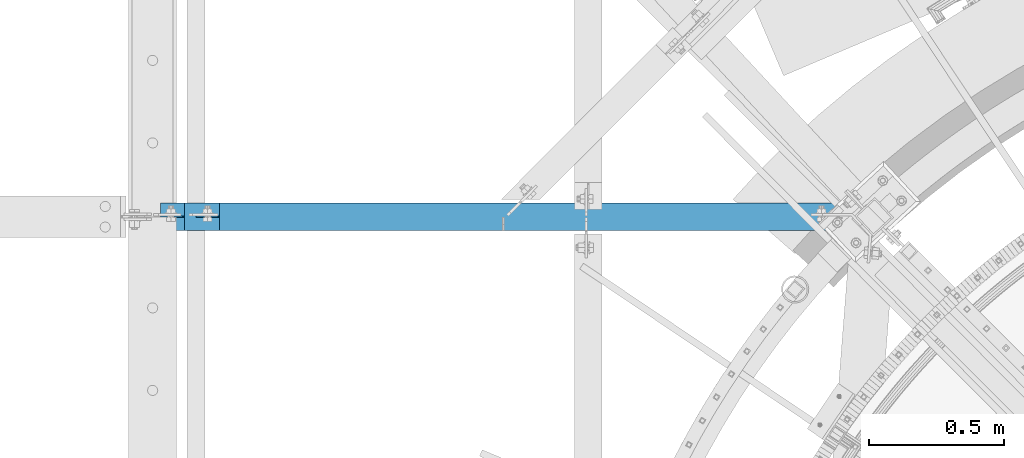
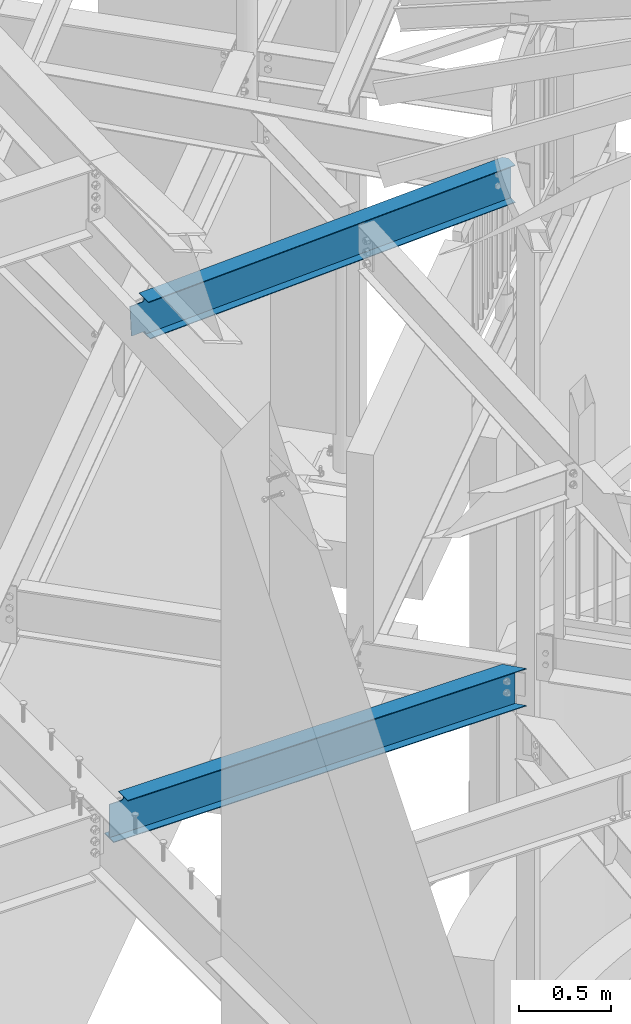
# One storey, part 342 of 975: 2 beams.
"""IFC2X3 building model written with IfcOpenShell, lengths in millimetres."""

from ifc_helpers import new_model, si_unit, frame, origin_with_axes, place, context, subcontext, project, spatial, faceted_brep, material, type_object, element, save


model = new_model("IFC2X3")

# Units and contexts
model_context = context("Model", 3, precision=1e-05, world=origin_with_axes())
body_context = subcontext(model_context, "Body", "Model", "MODEL_VIEW")
ifc_project = project(units=[si_unit("LENGTHUNIT", "METRE", prefix="MILLI"), si_unit("AREAUNIT", "SQUARE_METRE"), si_unit("VOLUMEUNIT", "CUBIC_METRE"), si_unit("MASSUNIT", "GRAM", prefix="KILO"), si_unit("TIMEUNIT", "SECOND"), si_unit("PLANEANGLEUNIT", "RADIAN"), si_unit("SOLIDANGLEUNIT", "STERADIAN"), si_unit("THERMODYNAMICTEMPERATUREUNIT", "DEGREE_CELSIUS"), si_unit("LUMINOUSINTENSITYUNIT", "LUMEN")], contexts=[model_context])

# Site, building, storey
site_placement = place(None, origin_with_axes())
site = spatial("IfcSite", under=ifc_project, at=site_placement, CompositionType="ELEMENT")
building_placement = place(site_placement, origin_with_axes())
building = spatial("IfcBuilding", under=site, at=building_placement, Name="Undefined", CompositionType="ELEMENT")
storey_placement = place(building_placement, origin_with_axes())
storey = spatial("IfcBuildingStorey", under=building, at=storey_placement, Name="Undefined", CompositionType="ELEMENT", Elevation=0.0)

# Beams
ifc_material = material(Name="STEEL/A992")
beam_type = type_object("IfcBeamType", Name="W10X12", PredefinedType="NOTDEFINED")
beam_1_placement = place(storey_placement, frame((29964.9410145014, 5819.77499996243, 7075.61443343476), z_axis=(-0.0449796829949373, 0.0, 0.998987901887543), x_axis=(0.998987901887543, 0.0, 0.0449796829949365)))
element("IfcBeam", 1, at=beam_1_placement, inside=storey, type_object=beam_type, material=ifc_material, Name="BEAM", ObjectType="W10X12", context=body_context, shape_type="Brep", body=[
    faceted_brep([(31.7821272325964, -2.38125000000036, -100.012500000392), (31.7821272325964, 2.38125000000036, -100.012500000392), (107.982127435454, 2.37414132749745, -100.012500000514), (107.982127435454, -2.38125000000036, -100.012500000514), (112.842206953494, 2.37414170163174, -100.979229923104), (112.842206953494, -2.38125000000036, -100.979229923104), (116.962383421644, 2.37413946309971, -103.732243823584), (116.962383421644, -2.38125000000036, -103.732243823584), (119.715397322125, 2.3741349526972, -107.852420291742), (119.715397322125, -2.38125000000036, -107.852420291742), (120.68212724472, -2.38125000000036, -112.71249980979), (120.68212724472, 2.37412885709273, -112.71249980979), (120.682127244723, 2.36192703598772, -120.649999999969), (120.682127244723, 50.8000000000002, -120.649999999969), (120.682127244723, 50.8000000000002, -125.412499999969), (120.682127244723, -50.8000000000002, -125.412499999969), (120.682127244723, -50.8000000000002, -120.649999999969), (120.682127244723, -2.38125000000036, -120.649999999969), (2420.15431038327, 25.1579088831477, -120.650000048678), (2419.93987651427, 25.1579088831477, -125.412499999072), (2396.17930452123, 50.8000000000002, -125.412499999082), (2396.39373728849, 50.8000000000002, -120.64999999908), (2407.25833082956, 50.8000000000002, 120.650000000958), (2431.01890282259, 25.1579088831477, 120.650000000967), (2431.01890282259, 2.38125000000036, 120.650000000967), (120.682127243337, 2.3620972937515, 120.650000011137), (120.682127243341, 50.8000000000002, 120.650000000065), (107.982127434178, -2.38125000000036, 100.012499999661), (107.982127434178, 2.37406664749506, 100.012499999661), (31.7821272324218, 2.38125000000036, 100.012499999564), (31.7821272324218, -2.38125000000036, 100.012499999564), (112.842206952209, -2.38125000000036, 100.979229922245), (112.842206952209, 2.3740673684033, 100.979229922245), (116.962383420345, -2.38125000000036, 103.732243822723), (116.962383420345, 2.37406786749216, 103.732243822723), (119.715397320808, -2.38125000000036, 107.852420290877), (119.715397320808, 2.37406806878062, 107.852420290877), (120.682127243381, -2.38125000000036, 112.712499808924), (120.682127243381, 2.37406794162507, 112.712499808924), (2431.23333558985, -50.8000000000002, 125.412500000969), (2431.23333669159, 25.1579088831477, 125.412499951363), (2407.47276359681, 50.8000000000002, 125.41250000096), (120.682127243337, 50.8000000000002, 125.412500000067), (120.682127243337, -50.8000000000002, 125.412500000067), (2431.01890282259, -50.8000000000002, 120.650000000967), (120.682127243341, -50.8000000000002, 120.650000000065), (2431.01890282259, -2.38125000000036, 120.650000000967), (120.682127243341, -2.38125000000036, 120.650000000065), (2420.15430928153, -2.38125000000036, -120.649999999071), (2420.15430928153, -50.8000000000002, -120.649999999071), (2419.93987651427, -50.8000000000002, -125.412499999072), (2420.15430928153, 2.38125000000036, -120.649999999071)], [[[0, 1, 2, 3]], [[3, 2, 4, 5]], [[5, 4, 6, 7]], [[7, 6, 8, 9]], [[10, 11, 12, 13, 14, 15, 16, 17]], [[9, 8, 11, 10]], [[18, 19, 20, 21]], [[22, 23, 24, 25, 26]], [[27, 28, 29, 30]], [[31, 32, 28, 27]], [[33, 34, 32, 31]], [[35, 36, 34, 33]], [[37, 38, 36, 35]], [[39, 40, 41, 42, 43]], [[44, 39, 43, 45]], [[46, 44, 45, 47]], [[43, 42, 26, 25, 38, 37, 47, 45]], [[41, 22, 26, 42]], [[40, 23, 22, 41]], [[39, 44, 46, 48, 49, 50, 19, 18, 51, 24, 23, 40]], [[49, 48, 17, 16]], [[50, 49, 16, 15]], [[20, 19, 50, 15, 14]], [[21, 20, 14, 13]], [[51, 18, 21, 13, 12]], [[6, 4, 2, 1, 29, 28, 32, 34, 36, 38, 25, 24, 51, 12, 11, 8]], [[30, 29, 1, 0]], [[48, 46, 47, 37, 35, 33, 31, 27, 30, 0, 3, 5, 7, 9, 10, 17]]]),
])
beam_2_placement = place(storey_placement, frame((29832.3, 5819.775, 3811.5875), z_axis=(0.0, 0.0, 1.0), x_axis=(1.0, 0.0, 0.0)))
element("IfcBeam", 2, at=beam_2_placement, inside=storey, type_object=beam_type, material=ifc_material, Name="BEAM", ObjectType="W10X12", context=body_context, shape_type="Brep", body=[
    faceted_brep([(29.3687500000015, -2.38125000000036, -120.65), (29.3687500000015, -50.8000000000002, -120.65), (2626.07532061843, -50.8000000000002, -120.65), (2581.25476102389, -2.38125000000036, -120.65), (29.3687500000015, -50.8000000000002, -125.4125), (2626.07532061843, -50.8000000000002, -125.4125), (29.3687500000015, 50.8000000000002, -125.4125), (2532.0256217971, 50.8000000000002, -125.4125), (29.3687500000015, 50.8000000000002, -120.65), (2532.0256217971, 50.8000000000002, -120.65), (2576.84618139164, 2.38125000000036, -120.65), (2576.84618139164, 2.38125000000036, 120.65), (2532.0256217971, 50.8000000000002, 120.65), (2532.0256217971, 50.8000000000002, 125.4125), (2626.07532061843, -50.8000000000002, 125.4125), (2626.07532061843, -50.8000000000002, 120.65), (2581.25476102389, -2.38125000000036, 120.65), (29.3687500000015, 2.38125000000036, -120.65), (110.428829708788, -2.38125000000036, 100.979229922588), (110.428829708788, 2.38125000000036, 100.979229922588), (105.568750190741, 2.38125000000036, 100.0125), (105.568750190741, -2.38125000000036, 100.0125), (114.549006176941, -2.38125000000036, 103.732243823066), (114.549006176941, 2.38125000000036, 103.732243823066), (117.302020077419, -2.38125000000036, 107.85242029122), (117.302020077419, 2.38125000000036, 107.85242029122), (118.268750000007, -2.38125000000036, 112.712499809265), (118.268750000007, 2.38125000000036, 112.712499809265), (29.3687500000015, 2.38125000000036, 100.0125), (118.268750000007, 2.38125000000036, 120.65), (118.268750000007, 50.8000000000002, 120.65), (118.268750000007, 50.8000000000002, 125.4125), (118.268750000007, -50.8000000000002, 125.41249981212), (118.268750000007, -50.8000000000002, 120.65), (118.268750000007, -2.38125000000036, 120.65), (29.3687500000015, -2.38125000000036, 100.0125)], [[[0, 1, 2, 3]], [[1, 4, 5, 2]], [[4, 6, 7, 5]], [[6, 8, 9, 7]], [[10, 11, 12, 13, 14, 15, 16, 3, 2, 5, 7, 9]], [[8, 17, 10, 9]], [[18, 19, 20, 21]], [[22, 23, 19, 18]], [[24, 25, 23, 22]], [[26, 27, 25, 24]], [[11, 10, 17, 28, 20, 19, 23, 25, 27, 29]], [[12, 11, 29, 30]], [[13, 12, 30, 31]], [[14, 13, 31, 32]], [[15, 14, 32, 33]], [[16, 15, 33, 34]], [[32, 31, 30, 29, 27, 26, 34, 33]], [[24, 22, 18, 21, 35, 0, 3, 16, 34, 26]], [[17, 8, 6, 4, 1, 0, 35, 28]], [[21, 20, 28, 35]]]),
])

save(model, "model.ifc")
